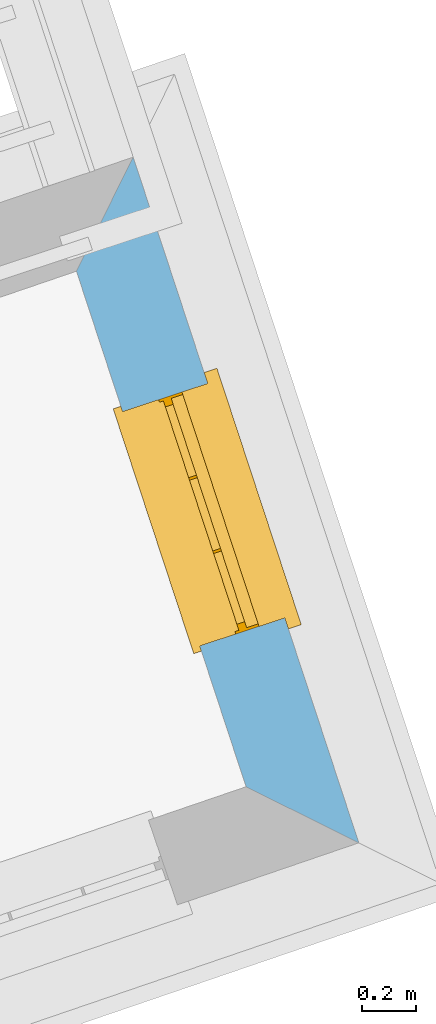
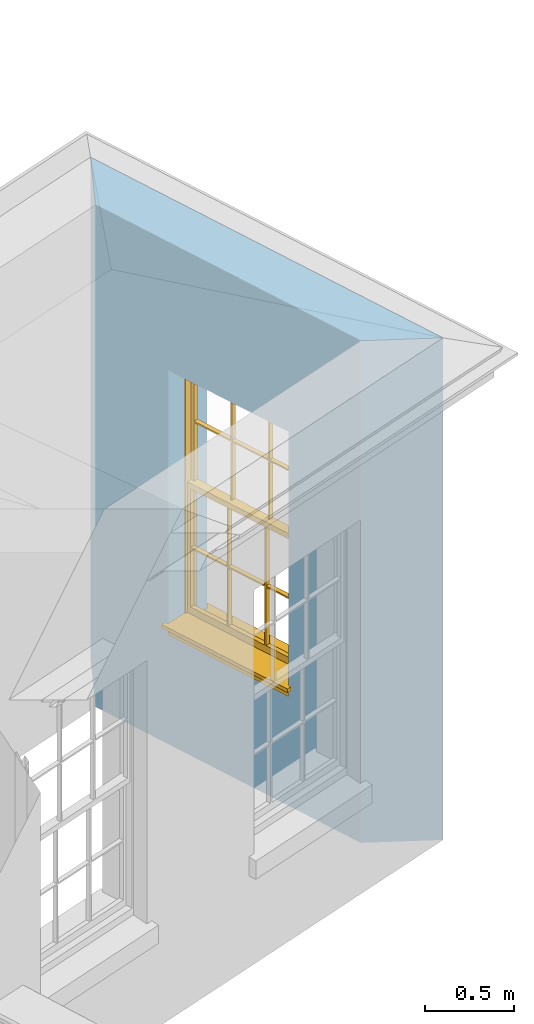
# One storey, part 8 of 10: 1 window, 1 opening, plus 1 element that does not belong to this part.
"""IFC2X3 building model written with IfcOpenShell, lengths in metres."""

from ifc_helpers import new_model, si_unit, frame, origin, place, context, subcontext, project, spatial, polyline, outline, extrude, faceted_brep, material, layer, layer_set, layer_usage, element, fill, save


model = new_model("IFC2X3")

# Units and contexts
model_context = context("Model", 3, world=origin())
body_context = subcontext(model_context, "Body", "Model", "MODEL_VIEW")
ifc_project = project(units=[si_unit("PLANEANGLEUNIT", "RADIAN"), si_unit("MASSUNIT", "GRAM", prefix="KILO"), si_unit("FORCEUNIT", "NEWTON", prefix="KILO"), si_unit("LENGTHUNIT", "METRE")], contexts=[model_context])

# Site, building, storey
site_placement = place(None, origin())
site = spatial("IfcSite", under=ifc_project, at=site_placement, CompositionType="ELEMENT")
building_placement = place(None, origin())
building = spatial("IfcBuilding", under=site, at=building_placement, Name="Building plot-2", CompositionType="ELEMENT")
storey_placement = place(None, frame((0.0, 0.0, 8.2)))
storey = spatial("IfcBuildingStorey", under=building, at=storey_placement, Name="Floor 2", CompositionType="ELEMENT", Elevation=8.2)

# Wall, opening, window
ifc_material = material(Name="Masonry")
ifc_layer = layer(ifc_material, 0.33, ventilated=False)
ifc_layer_set = layer_set([ifc_layer], Name="My Wall")
ifc_layer_usage = layer_usage(ifc_layer_set, "AXIS2", "NEGATIVE", 0.08)
wall_placement = place(storey_placement, origin())
wall = element("IfcWallStandardCase", 1, at=wall_placement, inside=storey, material=ifc_layer_usage, Name="exterior", context=body_context, shape_type="SweptSolid", body=[
    extrude(outline(polyline([(36.6893138301649, 33.9125007833851), (37.1047195485034, 33.7057805140381), (36.2732006834394, 36.2333480972997), (36.0640612033558, 35.8130809593384), (36.6893138301649, 33.9125007833851)])), origin(), (0.0, 0.0, 1.0), 3.45),
])
opening_placement = place(storey_placement, frame((0.0, 0.0, 0.75)))
opening = element("IfcOpeningElement", 2, at=opening_placement, cuts=wall, Name="Opening", ObjectType="Opening", context=body_context, shape_type="SweptSolid", body=[
    extrude(outline(polyline([(36.8320581914572, 34.5345891391136), (36.5476800507436, 35.3990132671227), (36.2342075647623, 35.2958871281825), (36.5185857054759, 34.4314630001735), (36.8320581914572, 34.5345891391136)])), origin(), (0.0, 0.0, 1.0), 1.82),
])
window_placement = place(storey_placement, frame((36.5945790354108, 34.4564632762802, 0.75), z_axis=(0.0, 0.0, 1.0), x_axis=(-0.284378140713635, 0.864424128009077, 0.0)))
window = element("IfcWindow", 3, at=window_placement, inside=storey, Name="circulation outside window", OverallHeight=1.82, OverallWidth=0.91, context=body_context, shape_type="Brep", held_by="IfcProductRepresentation", body=[
    faceted_brep([(0.033125, -0.105, 0.975209), (0.01, -0.105, 0.975209), (0.033125, -0.105, 1.376042), (0.876875, -0.105, 0.975209), (0.876875, -0.105, 1.376042), (0.9, -0.105, 0.975209), (0.876875, -0.105, 1.386042), (0.876875, -0.105, 1.786875), (0.9, -0.105, 1.81), (0.033125, -0.105, 1.786875), (0.033125, -0.105, 1.386042), (0.01, -0.105, 1.81), (0.876875, -0.135, 1.376042), (0.876875, -0.135, 0.975209), (0.9, -0.135, 0.937083), (0.033125, -0.135, 1.786875), (0.01, -0.135, 1.81), (0.033125, -0.135, 1.386042), (0.01, -0.135, 0.937083), (0.033125, -0.135, 0.975209), (0.033125, -0.135, 1.376042), (0.876875, -0.135, 1.786875), (0.876875, -0.135, 1.386042), (0.9, -0.135, 1.81), (0.033125, -0.105, 0.937083), (0.01, -0.105, 0.937083), (0.033125, -0.105, 0.53625), (0.876875, -0.105, 0.937083), (0.876875, -0.105, 0.53625), (0.9, -0.105, 0.937083), (0.876875, -0.105, 0.52625), (0.876875, -0.105, 0.125417), (0.9, -0.105, 0.077167), (0.033125, -0.105, 0.125417), (0.033125, -0.105, 0.52625), (0.01, -0.105, 0.077167), (-0.0425, -0.25, 0.01), (-0.0425, -0.3, 0.001667), (0.0, -0.25, 0.01), (0.9525, -0.25, 0.01), (0.91, -0.25, 0.01), (0.9525, -0.3, 0.001667), (-0.02, 0.08, 0.077167), (0.0, 0.08, 0.077167), (-0.02, 0.11, 0.077167), (0.0, -0.06, 0.077167), (0.01, -0.06, 0.077167), (0.91, -0.06, 0.077167), (0.91, 0.08, 0.077167), (0.9, -0.06, 0.077167), (0.93, 0.08, 0.077167), (0.93, 0.11, 0.077167), (0.01, -0.075, 0.975209), (0.9, -0.075, 0.975209), (0.876875, -0.075, 0.125417), (0.876875, -0.075, 0.52625), (0.9, -0.075, 0.077167), (0.876875, -0.075, 0.53625), (0.876875, -0.075, 0.937083), (0.033125, -0.075, 0.125417), (0.01, -0.075, 0.077167), (0.033125, -0.075, 0.52625), (0.033125, -0.075, 0.937083), (0.033125, -0.075, 0.53625), (-0.02, 0.08, 0.052167), (-0.02, 0.11, 0.052167), (0.93, 0.11, 0.052167), (0.93, 0.08, 0.052167), (0.91, 0.08, 0.052167), (0.0, 0.08, 0.052167), (0.91, -0.15, 0.026667), (0.0, -0.15, 0.026667), (-0.0425, -0.3, -0.123333), (0.9525, -0.3, -0.123333), (-0.0425, -0.25, -0.123333), (0.9525, -0.25, -0.123333), (0.01, -0.06, 1.81), (0.9, -0.06, 1.81), (0.0, -0.06, 1.82), (0.91, -0.06, 1.82), (0.01, -0.15, 0.077167), (0.9, -0.15, 0.077167), (0.592292, -0.105, 0.125417), (0.592292, -0.075, 0.125417), (0.317708, -0.075, 0.125417), (0.317708, -0.105, 0.125417), (0.592292, -0.105, 0.53625), (0.317708, -0.105, 0.53625), (0.317708, -0.105, 0.52625), (0.592292, -0.105, 0.52625), (0.592292, -0.075, 0.53625), (0.317708, -0.075, 0.53625), (0.592292, -0.135, 1.386042), (0.592292, -0.105, 1.386042), (0.317708, -0.105, 1.386042), (0.317708, -0.135, 1.386042), (0.317708, -0.135, 1.376042), (0.592292, -0.135, 1.376042), (0.317708, -0.105, 1.376042), (0.592292, -0.105, 1.376042), (0.602292, -0.135, 1.376042), (0.592292, -0.135, 0.975209), (0.602292, -0.135, 0.975209), (0.602292, -0.105, 0.975209), (0.592292, -0.105, 0.975209), (0.602292, -0.105, 1.376042), (0.602292, -0.075, 0.53625), (0.602292, -0.105, 0.53625), (0.317708, -0.075, 0.52625), (0.307708, -0.075, 0.125417), (0.307708, -0.075, 0.52625), (0.602292, -0.075, 0.52625), (0.602292, -0.075, 0.125417), (0.592292, -0.075, 0.52625), (0.307708, -0.075, 0.53625), (0.317708, -0.075, 0.937083), (0.307708, -0.075, 0.937083), (0.602292, -0.075, 0.937083), (0.592292, -0.075, 0.937083), (0.307708, -0.105, 0.52625), (0.307708, -0.105, 0.125417), (0.307708, -0.105, 0.53625), (0.307708, -0.105, 0.937083), (0.592292, -0.105, 0.937083), (0.317708, -0.105, 0.937083), (0.602292, -0.105, 0.937083), (0.602292, -0.105, 0.52625), (0.602292, -0.105, 0.125417), (0.307708, -0.135, 1.386042), (0.307708, -0.135, 1.376042), (0.307708, -0.135, 0.975209), (0.317708, -0.135, 0.975209), (0.317708, -0.135, 1.786875), (0.307708, -0.135, 1.786875), (0.602292, -0.135, 1.786875), (0.592292, -0.135, 1.786875), (0.602292, -0.135, 1.386042), (0.602292, -0.105, 1.386042), (0.307708, -0.105, 1.386042), (0.307708, -0.105, 1.786875), (0.317708, -0.105, 1.786875), (0.592292, -0.105, 1.786875), (0.602292, -0.105, 1.786875), (0.307708, -0.105, 1.376042), (0.317708, -0.105, 0.975209), (0.307708, -0.105, 0.975209), (0.91, -0.15, 1.82), (0.9, -0.15, 1.81), (0.01, -0.15, 1.81), (0.0, -0.15, 1.82), (0.91, -0.25, 0.0), (0.0, -0.25, 0.0), (0.91, 0.08, 0.0), (0.0, 0.08, 0.0)], [[[0, 1, 2]], [[3, 4, 5]], [[6, 7, 8]], [[9, 10, 11]], [[12, 13, 14]], [[15, 16, 17]], [[18, 19, 20]], [[21, 22, 23]], [[24, 25, 26]], [[27, 28, 29]], [[30, 31, 32]], [[33, 34, 35]], [[14, 27, 29]], [[25, 24, 18]], [[36, 37, 38]], [[39, 40, 41]], [[42, 43, 44]], [[45, 46, 43]], [[47, 48, 49]], [[50, 51, 48]], [[1, 0, 52]], [[5, 53, 3]], [[54, 55, 56]], [[57, 58, 53]], [[59, 60, 61]], [[62, 63, 52]], [[48, 43, 46, 49]], [[51, 44, 43, 48]], [[64, 42, 44, 65]], [[65, 44, 51, 66]], [[66, 51, 50, 67]], [[65, 66, 68, 69]], [[60, 56, 49, 46]], [[70, 71, 38, 40]], [[37, 41, 40, 38]], [[37, 72, 73, 41]], [[74, 75, 73, 72]], [[8, 11, 76, 77]], [[76, 78, 79, 77]], [[32, 35, 80, 81]], [[81, 80, 71, 70]], [[82, 83, 84, 85]], [[86, 87, 88, 89]], [[86, 90, 91, 87]], [[92, 93, 94, 95]], [[92, 95, 96, 97]], [[96, 98, 99, 97]], [[100, 97, 101, 102]], [[103, 104, 99, 105]], [[97, 99, 104, 101]], [[102, 103, 105, 100]], [[28, 57, 106, 107]], [[108, 84, 109, 110]], [[111, 112, 83, 113]], [[114, 110, 61, 63]], [[90, 113, 108, 91]], [[115, 91, 114, 116]], [[117, 106, 90, 118]], [[111, 106, 57, 55]], [[119, 110, 109, 120]], [[34, 61, 110, 119]], [[89, 113, 83, 82]], [[88, 108, 113, 89]], [[85, 84, 108, 88]], [[121, 114, 63, 26]], [[122, 116, 114, 121]], [[123, 118, 90, 86]], [[87, 91, 115, 124]], [[107, 106, 117, 125]], [[126, 111, 55, 30]], [[127, 112, 111, 126]], [[126, 30, 28, 107]], [[88, 119, 120, 85]], [[126, 89, 82, 127]], [[125, 123, 86, 107]], [[121, 26, 34, 119]], [[124, 122, 121, 87]], [[128, 17, 20, 129]], [[96, 129, 130, 131]], [[132, 133, 128, 95]], [[134, 135, 92, 136]], [[100, 12, 22, 136]], [[137, 6, 4, 105]], [[94, 138, 139, 140]], [[137, 93, 141, 142]], [[99, 98, 94, 93]], [[143, 2, 10, 138]], [[144, 145, 143, 98]], [[129, 143, 145, 130]], [[20, 2, 143, 129]], [[131, 144, 98, 96]], [[128, 138, 10, 17]], [[133, 139, 138, 128]], [[135, 141, 93, 92]], [[95, 94, 140, 132]], [[22, 6, 137, 136]], [[136, 137, 142, 134]], [[100, 105, 4, 12]], [[107, 86, 89, 126]], [[106, 111, 113, 90]], [[91, 108, 110, 114]], [[87, 121, 119, 88]], [[97, 100, 136, 92]], [[129, 96, 95, 128]], [[98, 143, 138, 94]], [[105, 99, 93, 137]], [[131, 101, 104, 144]], [[124, 115, 118, 123]], [[132, 140, 141, 135]], [[120, 109, 59, 33]], [[15, 9, 139, 133]], [[134, 142, 7, 21]], [[31, 54, 112, 127]], [[36, 74, 72, 37]], [[39, 41, 73, 75]], [[18, 14, 101, 131]], [[23, 16, 132, 135]], [[83, 56, 60, 84]], [[52, 53, 118, 115]], [[53, 52, 144, 104]], [[11, 8, 141, 140]], [[14, 18, 124, 123]], [[2, 1, 11, 10]], [[8, 5, 4, 6]], [[57, 53, 56, 55]], [[60, 52, 63, 61]], [[26, 25, 35, 34]], [[32, 29, 28, 30]], [[14, 23, 22, 12]], [[18, 20, 17, 16]], [[19, 0, 2, 20]], [[17, 10, 9, 15]], [[12, 4, 3, 13]], [[21, 7, 6, 22]], [[27, 58, 57, 28]], [[30, 55, 54, 31]], [[33, 59, 61, 34]], [[26, 63, 62, 24]], [[5, 8, 77, 53]], [[76, 11, 1, 52]], [[46, 45, 78, 76]], [[49, 77, 79, 47]], [[70, 146, 147, 81]], [[71, 80, 148, 149]], [[19, 130, 145, 0]], [[102, 13, 3, 103]], [[116, 122, 24, 62]], [[29, 32, 81, 14]], [[80, 35, 25, 18]], [[60, 46, 76, 52]], [[77, 49, 56, 53]], [[23, 14, 81, 147]], [[16, 148, 80, 18]], [[35, 85, 120]], [[120, 33, 35]], [[127, 82, 32]], [[32, 31, 127]], [[32, 82, 85, 35]], [[102, 101, 14]], [[14, 13, 102]], [[18, 131, 130]], [[130, 19, 18]], [[134, 21, 23]], [[23, 135, 134]], [[16, 15, 133]], [[133, 132, 16]], [[11, 140, 139]], [[139, 9, 11]], [[142, 141, 8]], [[8, 7, 142]], [[23, 147, 148, 16]], [[146, 149, 148, 147]], [[52, 115, 116]], [[116, 62, 52]], [[118, 53, 117]], [[58, 117, 53]], [[27, 125, 117, 58]], [[56, 83, 112]], [[112, 54, 56]], [[109, 84, 60]], [[60, 59, 109]], [[125, 27, 14]], [[14, 123, 125]], [[122, 124, 18]], [[18, 24, 122]], [[145, 144, 52]], [[52, 0, 145]], [[103, 3, 53]], [[53, 104, 103]], [[79, 78, 149, 146]], [[78, 45, 71, 149]], [[146, 70, 47, 79]], [[150, 75, 74, 151]], [[68, 66, 67]], [[48, 68, 67, 50]], [[69, 64, 65]], [[42, 64, 69, 43]], [[69, 68, 152, 153]], [[70, 68, 48, 47]], [[150, 152, 68, 70]], [[43, 69, 71, 45]], [[69, 153, 151, 71]], [[152, 150, 151, 153]], [[38, 151, 74, 36]], [[71, 151, 38]], [[39, 75, 150, 40]], [[40, 150, 70]]]),
])
fill(opening, window)

save(model, "model.ifc")
